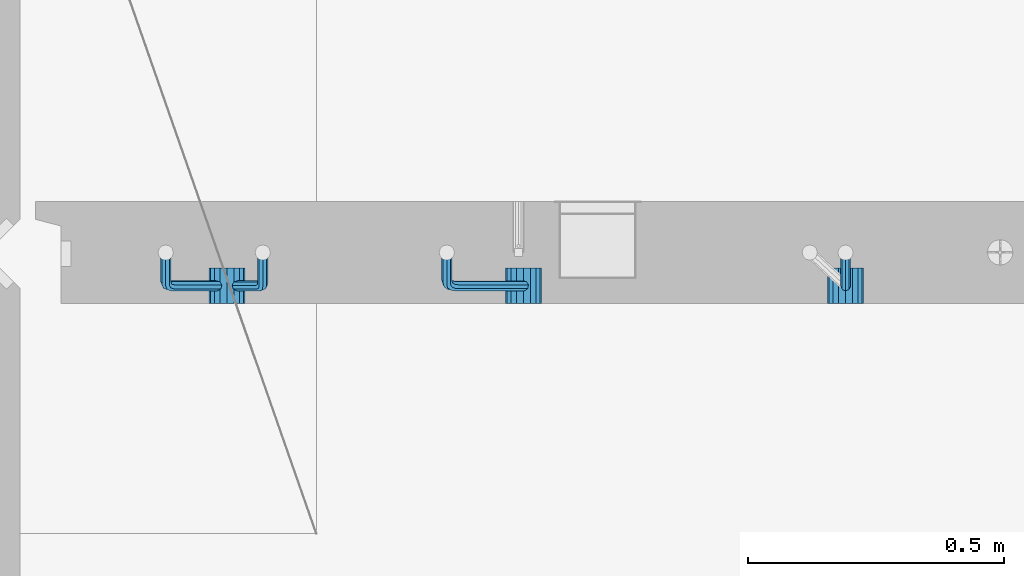
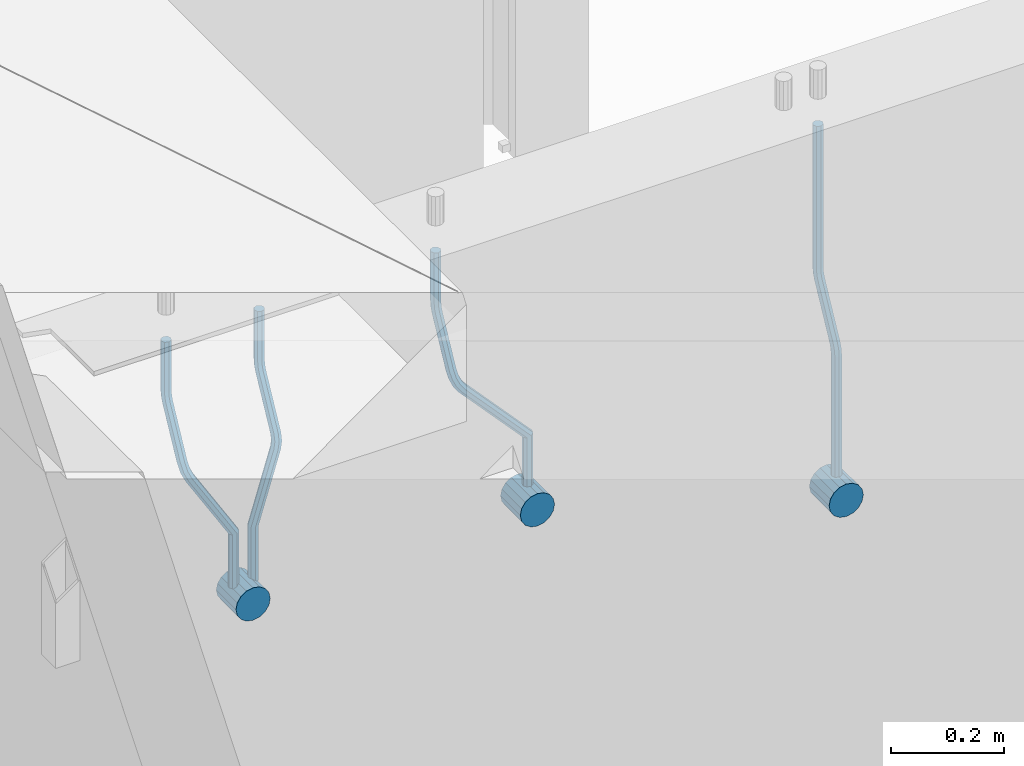
# One storey, part 155 of 349: 7 beams, 1 element without a shape of its own.
"""IFC2X3 building model written with IfcOpenShell, lengths in millimetres."""

from ifc_helpers import new_model, si_unit, frame, origin_with_axes, place, context, subcontext, project, spatial, faceted_brep, material, type_object, element, aggregate, save


model = new_model("IFC2X3")

# Units and contexts
model_context = context("Model", 3, precision=1e-05, world=origin_with_axes())
body_context = subcontext(model_context, "Body", "Model", "MODEL_VIEW")
ifc_project = project(units=[si_unit("LENGTHUNIT", "METRE", prefix="MILLI"), si_unit("AREAUNIT", "SQUARE_METRE"), si_unit("VOLUMEUNIT", "CUBIC_METRE"), si_unit("MASSUNIT", "GRAM", prefix="KILO"), si_unit("TIMEUNIT", "SECOND"), si_unit("PLANEANGLEUNIT", "RADIAN"), si_unit("SOLIDANGLEUNIT", "STERADIAN"), si_unit("THERMODYNAMICTEMPERATUREUNIT", "DEGREE_CELSIUS"), si_unit("LUMINOUSINTENSITYUNIT", "LUMEN")], contexts=[model_context])

# Site, building, storey
site_placement = place(None, origin_with_axes())
site = spatial("IfcSite", under=ifc_project, at=site_placement, CompositionType="ELEMENT")
building_placement = place(site_placement, origin_with_axes())
building = spatial("IfcBuilding", under=site, at=building_placement, CompositionType="ELEMENT")
storey_placement = place(building_placement, origin_with_axes())
storey = spatial("IfcBuildingStorey", under=building, at=storey_placement, Name="4", CompositionType="ELEMENT", Elevation=0.0)

# Assembly, beams
assembly_placement = place(storey_placement, origin_with_axes())
assembly = element("IfcElementAssembly", 1, at=assembly_placement, inside=storey, AssemblyPlace="NOTDEFINED", PredefinedType="REINFORCEMENT_UNIT")
ifc_material = material()
beam_type_1 = type_object("IfcBeamType", Name="D20", PredefinedType="NOTDEFINED")
beam_1_placement = place(assembly_placement, frame((9615.0034031366, 16979.9000008034, 93407.5), z_axis=(-0.000415599999849952, -0.999999913638316, 0.0), x_axis=(0.0, 0.0, -1.0)))
beam_1 = element("IfcBeam", 2, at=beam_1_placement, type_object=beam_type_1, material=ifc_material, Name="JM20", ObjectType="D20", context=body_context, shape_type="Brep", body=[
    faceted_brep([(0.0, -10.0, 0.0), (-4.19531716033816e-08, -7.07106781186667, -7.07106781187031), (308.817759199839, -7.07106784567077, -7.07106781098628), (308.817759199388, -10.0000000315576, 1.18961906991899e-09), (0.0, 0.0, -10.0), (308.817759200625, -3.38059180648997e-08, -9.99999999911961), (4.196772351861e-08, 7.07106781186303, -7.07106781186667), (308.817759201396, 7.07106777806075, -7.07106781098992), (0.0, 10.0, 0.0), (308.817759201687, 9.99999996619408, 8.76752892509103e-10), (4.196772351861e-08, 7.07106781185939, 7.07106781185939), (308.817759201353, 7.07106777805893, 7.07106781273978), (0.0, 0.0, 10.0), (308.817759200567, -3.38059180648997e-08, 10.0000000008768), (-4.19531716033816e-08, -7.07106781187031, 7.07106781185939), (308.817759199781, -7.07106784567259, 7.07106781274342), (323.108969574154, 0.000717635259206872, -8.27316123493802), (322.412036484602, -7.07038517474393, -5.42844102338131), (320.72809124495, -9.99940192615759, 1.43915193649809), (319.043566138222, -7.07055433041933, 8.30667482965873), (318.345233125816, 0.000478413006931078, 11.1512258851908), (319.042166215368, 7.07158122300643, 8.30650567364501), (320.726111455049, 10.0005979744237, 1.4389127137656), (322.410636561748, 7.07175037869092, -5.42861017940231), (335.221090258594, 7.07375888522984, -0.59577927861028), (336.577559329642, 0.00282932867594354, -3.19204402394098), (331.949003496353, 10.0023575726736, 5.67282516818887), (328.678043090971, 7.07309199865631, 11.9417058486688), (327.324293285914, 0.00188620863991673, 14.5386374811205), (328.680762356948, -7.06904334791398, 11.9423727357971), (331.952849119407, -9.99764203791528, 5.67376828873239), (335.223809524556, -7.06837646134409, -0.59511239150379), (438.031978881656, -7.04607830785426, 53.0582885393342), (434.761018476231, -9.97534387865016, 59.3271692200688), (439.385728686641, 0.0251274821457628, 50.4613569068679), (438.02925961549, 7.0960570387233, 53.0576216521513), (434.757172853177, 10.0246557262235, 59.326226098925), (431.486212447766, 7.0953901522571, 65.5951067794085), (430.132462642781, 0.0241843622607121, 68.1920384118748), (431.488931713931, -7.04674519431865, 65.5957736665914), (448.364788846782, 0.0265352911246737, 53.8487685030559), (447.667855771331, -7.04456751813632, 56.6934887198913), (445.983910537514, -9.97358426776555, 63.5610816819462), (444.29938542498, -7.04473667025195, 70.428604572935), (443.601052398531, 0.0262960739091795, 73.2731556232175), (444.297985473939, 7.09739888316835, 70.4284354063821), (445.981930707741, 10.0264156328012, 63.5608424443053), (447.666455820276, 7.09756803528398, 56.6933195533311), (457.892262743961, 7.0980815803614, 57.9289265681182), (457.892262772089, 0.0270137655697908, 54.999994387068), (457.892262732348, 10.0270137755506, 64.9999943770345), (457.892262744092, 7.09808159448221, 72.0710621918224), (457.89226277222, 0.0270137855477515, 74.9999943870425), (457.89226280032, -7.04405402924385, 72.0710622060069), (457.892262811918, -9.97298622770904, 64.9999943967923), (457.892262800189, -7.04405404336103, 57.9289265822954), (717.500000028129, -7.04405301280349, 57.928926581666), (717.500000039799, -9.97298519384276, 64.9999943964685), (717.499999999956, 0.0270147961218754, 54.999994386435), (717.499999971798, 7.09808261092803, 57.9289265674743), (717.499999960128, 10.0270148061572, 64.9999943763978), (717.499999971813, 7.09808262511979, 72.071062191204), (717.499999999985, 0.0270148161926045, 74.999994386435), (717.500000028143, -7.04405299861173, 72.0710622053957)], [[[0, 1, 2, 3]], [[1, 4, 5, 2]], [[4, 6, 7, 5]], [[6, 8, 9, 7]], [[8, 10, 11, 9]], [[10, 12, 13, 11]], [[12, 14, 15, 13]], [[14, 0, 3, 15]], [[14, 12, 10, 8, 6, 4, 1, 0]], [[2, 5, 16, 17]], [[3, 2, 17, 18]], [[15, 3, 18, 19]], [[13, 15, 19, 20]], [[11, 13, 20, 21]], [[9, 11, 21, 22]], [[7, 9, 22, 23]], [[5, 7, 23, 16]], [[23, 24, 25, 16]], [[22, 26, 24, 23]], [[21, 27, 26, 22]], [[20, 28, 27, 21]], [[19, 29, 28, 20]], [[18, 30, 29, 19]], [[17, 31, 30, 18]], [[16, 25, 31, 17]], [[30, 31, 32, 33]], [[31, 25, 34, 32]], [[25, 24, 35, 34]], [[24, 26, 36, 35]], [[26, 27, 37, 36]], [[27, 28, 38, 37]], [[28, 29, 39, 38]], [[29, 30, 33, 39]], [[32, 34, 40, 41]], [[33, 32, 41, 42]], [[39, 33, 42, 43]], [[38, 39, 43, 44]], [[37, 38, 44, 45]], [[36, 37, 45, 46]], [[35, 36, 46, 47]], [[34, 35, 47, 40]], [[47, 48, 49, 40]], [[46, 50, 48, 47]], [[45, 51, 50, 46]], [[44, 52, 51, 45]], [[43, 53, 52, 44]], [[42, 54, 53, 43]], [[41, 55, 54, 42]], [[40, 49, 55, 41]], [[54, 55, 56, 57]], [[55, 49, 58, 56]], [[49, 48, 59, 58]], [[48, 50, 60, 59]], [[50, 51, 61, 60]], [[51, 52, 62, 61]], [[52, 53, 63, 62]], [[53, 54, 57, 63]], [[58, 59, 60, 61, 62, 63, 57, 56]]]),
])
beam_2_placement = place(assembly_placement, frame((8835.00340324668, 16979.9000008034, 93407.5), z_axis=(-0.000415599999849952, -0.999999913638316, 0.0), x_axis=(0.0, 0.0, -1.0)))
beam_2 = element("IfcBeam", 3, at=beam_2_placement, type_object=beam_type_1, material=ifc_material, Name="JM20", ObjectType="D20", context=body_context, shape_type="Brep", body=[
    faceted_brep([(0.0, -10.0, 0.0), (-4.19531716033816e-08, -7.07106781186667, -7.07106781187031), (108.817745274035, -7.07106780534923, -7.07106781138282), (108.817745274282, -9.99999999387728, 6.25732354819775e-10), (0.0, 0.0, -10.0), (108.817745273627, 6.5174390329048e-09, -9.99999999951979), (4.196772351861e-08, 7.07106781186303, -7.07106781186667), (108.817745273191, 7.07106781838229, -7.07106781138646), (0.0, 10.0, 0.0), (108.817745272972, 10.0000000065156, 4.80213202536106e-10), (4.196772351861e-08, 7.07106781185939, 7.07106781185939), (108.817745273118, 7.07106781838047, 7.07106781234688), (0.0, 0.0, 10.0), (108.817745273511, 6.51562004350126e-09, 10.0000000004839), (-4.19531716033816e-08, -7.07106781187031, 7.07106781185939), (108.817745273947, -7.07106780535105, 7.07106781234688), (123.108954183059, 0.000717681035894202, -8.27316159443217), (122.412021172189, -7.07038512938016, -5.42844136475105), (120.72807610796, -9.99940188179062, 1.43915163770362), (119.043551170704, -7.07055428705462, 8.30667457294476), (118.345218222516, 0.000478455955089885, 11.1512256454189), (119.0421512334, 7.07158126637114, 8.30650541574869), (120.726096297614, 10.0005980187834, 1.43891241329038), (122.410621234856, 7.0717504240456, -5.42861052196531), (135.22107377628, 7.07375894905454, -0.595780608462519), (136.577542729705, 0.00282939387761871, -3.19204541917861), (131.948987323645, 10.0023576331841, 5.67282400158729), (128.678027238435, 7.07309205585807, 11.9417048475552), (127.324277576598, 0.00188626447015849, 14.5386365507547), (128.680746529979, -7.06904329070858, 11.9423717400241), (131.952832982774, -9.99764197422519, 5.67376712984333), (135.223793067897, -7.06837639751029, -0.595113715968182), (228.618473932263, -7.04811975626581, 48.1455814515648), (225.347513847039, -9.97738533437769, 54.4144622980784), (229.972223594217, 0.0230860351002775, 45.5486497482525), (228.615754640981, 7.0940155903063, 48.1449145588849), (225.343668188434, 10.0226142745032, 54.413519168902), (222.072708103209, 7.0933486972317, 60.6824000149136), (220.71895844127, 0.0221429058692593, 63.2793317182222), (222.075427394506, -7.04878664933858, 60.6830669075935), (242.359530626607, -5.11807977741773, 54.2178725378544), (240.589998539246, -7.8364579297413, 61.1502473240325), (237.467032239641, -4.88691414189452, 67.4847494116439), (234.820023031163, 2.00274883800921, 69.5107133886158), (234.199553008453, 8.79665987653607, 66.041357034137), (235.9690850958, 11.515038028856, 59.108982247948), (239.092051395462, 8.56549424101649, 52.7744801603476), (241.739060603926, 1.67583126110367, 50.7485161833647), (253.320593995435, 6.49475796966908, 54.0461912154642), (255.884193780192, 0.509358169847474, 58.0688258176233), (249.403367901468, 12.8559000820806, 55.7104792064529), (246.427173417251, 15.8665137298067, 62.0867724571763), (246.135424907392, 13.7630222690877, 69.4399248590198), (248.699024692221, 7.77762246929342, 73.462559461208), (252.616250786203, 1.41648035689104, 71.7982714702011), (255.592445270362, -1.59413329085874, 65.4219782194778), (263.775218458322, 14.0880763316163, 55.1735662778046), (268.092877162446, 9.37667043252804, 59.3853499298057), (258.711370403718, 19.6164132468075, 56.7142082202008), (255.867666511243, 22.72325639054, 63.1047886019151), (256.909909953785, 21.588659185405, 70.6017921067651), (261.227568657952, 16.8772532863513, 74.8135757587734), (266.291416712571, 11.348916371182, 73.2729338163554), (269.135120604697, 8.24207322799703, 66.8823534341354), (411.777331932535, 141.004054536572, 59.330645583992), (412.819575375106, 139.86945733149, 66.8276490888165), (407.459673228295, 145.71546043558, 55.1188619320019), (402.395825173633, 151.243797350722, 56.6595038743981), (399.552121281173, 154.350640494475, 63.0500842560868), (400.594364723744, 153.216043289394, 70.547087760915), (404.912023427984, 148.504637390388, 74.7588714129015), (409.975871482646, 142.976300475242, 73.2182294705053), (412.588360762704, 141.747027069805, 59.3303368045817), (413.18825896435, 140.207203377095, 66.8275087215443), (410.103187350978, 148.137147940774, 55.1178554785947), (407.188519608899, 155.634319848998, 56.6576791731022), (405.551730369989, 159.846801170075, 63.047800051525), (406.151628571635, 158.306977477367, 70.5449719684912), (408.636801983361, 151.916856606398, 74.7574532944818), (411.551469725426, 144.419684698174, 73.2176295999743), (413.688258959737, 141.747027073105, 59.3303368045781), (413.68825896435, 140.207203378595, 66.8275087215443), (413.688258940572, 148.137147951529, 55.1178554785911), (413.688258918075, 155.634319868494, 56.6576791730986), (413.688258905444, 159.846801194481, 63.0478000515213), (413.688258910042, 158.306977499973, 70.5449719684912), (413.688258929222, 151.916856621549, 74.7574532944782), (413.688258951704, 144.419684704584, 73.2176295999707), (517.499999574822, 141.74702738449, 59.3303368045817), (517.499999579435, 140.207203689981, 66.8275087215443), (517.499999555657, 148.137148262915, 55.1178554785947), (517.499999533175, 155.634320179879, 56.6576791731022), (517.499999520529, 159.846801505866, 63.047800051525), (517.499999525127, 158.306977811359, 70.5449719684912), (517.499999544307, 151.916856932934, 74.7574532944818), (517.499999566789, 144.41968501597, 73.2176295999743)], [[[0, 1, 2, 3]], [[1, 4, 5, 2]], [[4, 6, 7, 5]], [[6, 8, 9, 7]], [[8, 10, 11, 9]], [[10, 12, 13, 11]], [[12, 14, 15, 13]], [[14, 0, 3, 15]], [[14, 12, 10, 8, 6, 4, 1, 0]], [[2, 5, 16, 17]], [[3, 2, 17, 18]], [[15, 3, 18, 19]], [[13, 15, 19, 20]], [[11, 13, 20, 21]], [[9, 11, 21, 22]], [[7, 9, 22, 23]], [[5, 7, 23, 16]], [[23, 24, 25, 16]], [[22, 26, 24, 23]], [[21, 27, 26, 22]], [[20, 28, 27, 21]], [[19, 29, 28, 20]], [[18, 30, 29, 19]], [[17, 31, 30, 18]], [[16, 25, 31, 17]], [[30, 31, 32, 33]], [[31, 25, 34, 32]], [[25, 24, 35, 34]], [[24, 26, 36, 35]], [[26, 27, 37, 36]], [[27, 28, 38, 37]], [[28, 29, 39, 38]], [[29, 30, 33, 39]], [[33, 32, 40, 41]], [[39, 33, 41, 42]], [[38, 39, 42, 43]], [[37, 38, 43, 44]], [[36, 37, 44, 45]], [[35, 36, 45, 46]], [[34, 35, 46, 47]], [[32, 34, 47, 40]], [[47, 48, 49, 40]], [[46, 50, 48, 47]], [[45, 51, 50, 46]], [[44, 52, 51, 45]], [[43, 53, 52, 44]], [[42, 54, 53, 43]], [[41, 55, 54, 42]], [[40, 49, 55, 41]], [[48, 56, 57, 49]], [[50, 58, 56, 48]], [[51, 59, 58, 50]], [[52, 60, 59, 51]], [[53, 61, 60, 52]], [[54, 62, 61, 53]], [[55, 63, 62, 54]], [[49, 57, 63, 55]], [[63, 57, 64, 65]], [[57, 56, 66, 64]], [[56, 58, 67, 66]], [[58, 59, 68, 67]], [[59, 60, 69, 68]], [[60, 61, 70, 69]], [[61, 62, 71, 70]], [[62, 63, 65, 71]], [[65, 64, 72, 73]], [[64, 66, 74, 72]], [[66, 67, 75, 74]], [[67, 68, 76, 75]], [[68, 69, 77, 76]], [[69, 70, 78, 77]], [[70, 71, 79, 78]], [[71, 65, 73, 79]], [[73, 72, 80, 81]], [[72, 74, 82, 80]], [[74, 75, 83, 82]], [[75, 76, 84, 83]], [[76, 77, 85, 84]], [[77, 78, 86, 85]], [[78, 79, 87, 86]], [[79, 73, 81, 87]], [[81, 80, 88, 89]], [[80, 82, 90, 88]], [[82, 83, 91, 90]], [[83, 84, 92, 91]], [[84, 85, 93, 92]], [[85, 86, 94, 93]], [[86, 87, 95, 94]], [[87, 81, 89, 95]], [[90, 91, 92, 93, 94, 95, 89, 88]]]),
])
beam_3_placement = place(assembly_placement, frame((8475.00340324668, 16979.9000008034, 93407.5), z_axis=(-0.000415599999849952, -0.999999913638316, 0.0), x_axis=(0.0, 0.0, -1.0)))
beam_3 = element("IfcBeam", 4, at=beam_3_placement, type_object=beam_type_1, material=ifc_material, Name="JM20", ObjectType="D20", context=body_context, shape_type="Brep", body=[
    faceted_brep([(0.0, -10.0, 0.0), (-4.19531716033816e-08, -7.07106781186667, -7.07106781187031), (108.817745274035, -7.07106780534923, -7.07106781138282), (108.817745274282, -9.99999999387728, 6.25732354819775e-10), (0.0, 0.0, -10.0), (108.817745273627, 6.5174390329048e-09, -9.99999999951979), (4.196772351861e-08, 7.07106781186303, -7.07106781186667), (108.817745273191, 7.07106781838229, -7.07106781138646), (0.0, 10.0, 0.0), (108.817745272972, 10.0000000065156, 4.80213202536106e-10), (4.196772351861e-08, 7.07106781185939, 7.07106781185939), (108.817745273118, 7.07106781838047, 7.07106781234688), (0.0, 0.0, 10.0), (108.817745273511, 6.51562004350126e-09, 10.0000000004839), (-4.19531716033816e-08, -7.07106781187031, 7.07106781185939), (108.817745273947, -7.07106780535105, 7.07106781234688), (123.108954183059, 0.000717681035894202, -8.27316159443217), (122.412021172189, -7.07038512938016, -5.42844136475105), (120.72807610796, -9.99940188179062, 1.43915163770362), (119.043551170704, -7.07055428705462, 8.30667457294476), (118.345218222516, 0.000478455955089885, 11.1512256454189), (119.0421512334, 7.07158126637114, 8.30650541574869), (120.726096297614, 10.0005980187834, 1.43891241329038), (122.410621234856, 7.0717504240456, -5.42861052196531), (135.22107377628, 7.07375894905454, -0.595780608462519), (136.577542729705, 0.00282939387761871, -3.19204541917861), (131.948987323645, 10.0023576331841, 5.67282400158729), (128.678027238435, 7.07309205585807, 11.9417048475552), (127.324277576598, 0.00188626447015849, 14.5386365507547), (128.680746529979, -7.06904329070858, 11.9423717400241), (131.952832982774, -9.99764197422519, 5.67376712984333), (135.223793067897, -7.06837639751029, -0.595113715968182), (236.184987141853, -7.04647863304126, 52.0943835719445), (232.914027056744, -9.97574421112949, 58.3632644184945), (237.538736803792, 0.0247271583230031, 49.4974518686358), (236.182267850556, 7.09565671352902, 52.093716679261), (232.910181397994, 10.0242553977168, 58.3623212892744), (229.639221312784, 7.0949898204417, 64.631202135286), (228.28547165083, 0.0237840290774329, 67.2281338385947), (229.64194060408, -7.04714552612859, 64.6318690279659), (248.6361426574, 6.07228546495571, 56.8411920703111), (248.347225361111, -0.863437898962729, 53.6176983169717), (246.616285773896, -7.90364889308694, 56.0708434545886), (244.457284830249, -10.9242873990424, 62.7636083320067), (243.134936001807, -8.15590434705155, 69.7754620538217), (243.423853298023, -1.22018098313129, 72.9989558071647), (245.154792885252, 5.82003001100384, 70.5458106695442), (247.313793828915, 8.84066851695206, 63.8530457921224), (262.262810178814, 5.37582167724941, 65.733133839356), (261.561593060862, 3.07645584421334, 58.4667829613572), (261.257873569193, 2.08769693226714, 72.5710415482208), (259.135461468584, -4.86177950991259, 74.9749524903455), (257.138854100602, -11.4016986008392, 71.5366882385752), (256.437636982591, -13.7010644331713, 64.2703373600561), (257.442573592241, -10.4129396888893, 57.4324296517152), (259.564985692865, -3.46346324671867, 55.0285187095906), (405.56030258059, -55.6424869289785, 57.4512270528103), (404.555365971013, -58.9306116739535, 64.2891347616751), (407.682714681185, -48.6930104868225, 55.0473161106529), (409.679322049255, -42.153091395905, 58.4855803623905), (410.380539167294, -39.8537255628671, 65.7519312403674), (409.375602557717, -43.1418503078439, 72.5898389492322), (407.253190457122, -50.09132675, 74.993749891386), (405.256583089053, -56.6312458409175, 71.5554856396557), (408.394915116543, -56.5080702894629, 57.4515867892878), (407.881249744809, -59.9462106727442, 64.2895568446584), (409.479769216079, -49.2417629119063, 55.0475441721828), (410.500319225088, -42.4037928534744, 58.4856845539216), (410.858740789379, -39.9997502352981, 65.751991928224), (410.345075417616, -43.4378906185757, 72.5899619835945), (409.26022131808, -50.7041979961323, 74.9940046006996), (408.239671309086, -57.5421680545642, 71.5558642189608), (411.358740838899, -56.5080702805735, 57.4515867892915), (411.358740849202, -59.9462106623123, 64.2895568446584), (411.358740817101, -49.2417629062693, 55.0475441721828), (411.358740796582, -42.4037928508988, 58.4856845539216), (411.358740789379, -39.9997502337974, 65.751991928224), (411.358740799667, -43.4378906155343, 72.5899619835945), (411.358740821452, -50.7041979898386, 74.9940046006996), (411.35874084197, -57.5421680452091, 71.5558642189608), (527.500000169515, -56.5080699322043, 57.4515867892878), (527.500000179818, -59.9462103139449, 64.2895568446584), (527.500000147716, -49.2417625579019, 55.0475441721828), (527.500000127198, -42.4037925025295, 58.4856845539216), (527.500000119981, -39.9997498854282, 65.751991928224), (527.500000130283, -43.4378902671669, 72.5899619835945), (527.500000152068, -50.7041976414694, 74.9940046006996), (527.500000172586, -57.5421676968399, 71.5558642189608)], [[[0, 1, 2, 3]], [[1, 4, 5, 2]], [[4, 6, 7, 5]], [[6, 8, 9, 7]], [[8, 10, 11, 9]], [[10, 12, 13, 11]], [[12, 14, 15, 13]], [[14, 0, 3, 15]], [[14, 12, 10, 8, 6, 4, 1, 0]], [[2, 5, 16, 17]], [[3, 2, 17, 18]], [[15, 3, 18, 19]], [[13, 15, 19, 20]], [[11, 13, 20, 21]], [[9, 11, 21, 22]], [[7, 9, 22, 23]], [[5, 7, 23, 16]], [[23, 24, 25, 16]], [[22, 26, 24, 23]], [[21, 27, 26, 22]], [[20, 28, 27, 21]], [[19, 29, 28, 20]], [[18, 30, 29, 19]], [[17, 31, 30, 18]], [[16, 25, 31, 17]], [[30, 31, 32, 33]], [[31, 25, 34, 32]], [[25, 24, 35, 34]], [[24, 26, 36, 35]], [[26, 27, 37, 36]], [[27, 28, 38, 37]], [[28, 29, 39, 38]], [[29, 30, 33, 39]], [[34, 35, 40, 41]], [[32, 34, 41, 42]], [[33, 32, 42, 43]], [[39, 33, 43, 44]], [[38, 39, 44, 45]], [[37, 38, 45, 46]], [[36, 37, 46, 47]], [[35, 36, 47, 40]], [[47, 48, 49, 40]], [[46, 50, 48, 47]], [[45, 51, 50, 46]], [[44, 52, 51, 45]], [[43, 53, 52, 44]], [[42, 54, 53, 43]], [[41, 55, 54, 42]], [[40, 49, 55, 41]], [[53, 54, 56, 57]], [[54, 55, 58, 56]], [[55, 49, 59, 58]], [[49, 48, 60, 59]], [[48, 50, 61, 60]], [[50, 51, 62, 61]], [[51, 52, 63, 62]], [[52, 53, 57, 63]], [[57, 56, 64, 65]], [[56, 58, 66, 64]], [[58, 59, 67, 66]], [[59, 60, 68, 67]], [[60, 61, 69, 68]], [[61, 62, 70, 69]], [[62, 63, 71, 70]], [[63, 57, 65, 71]], [[65, 64, 72, 73]], [[64, 66, 74, 72]], [[66, 67, 75, 74]], [[67, 68, 76, 75]], [[68, 69, 77, 76]], [[69, 70, 78, 77]], [[70, 71, 79, 78]], [[71, 65, 73, 79]], [[73, 72, 80, 81]], [[72, 74, 82, 80]], [[74, 75, 83, 82]], [[75, 76, 84, 83]], [[76, 77, 85, 84]], [[77, 78, 86, 85]], [[78, 79, 87, 86]], [[79, 73, 81, 87]], [[82, 83, 84, 85, 86, 87, 81, 80]]]),
])
beam_4_placement = place(assembly_placement, frame((8285.00340324668, 16979.9000008034, 93407.5), z_axis=(-0.000415599999849952, -0.999999913638316, 0.0), x_axis=(0.0, 0.0, -1.0)))
beam_4 = element("IfcBeam", 5, at=beam_4_placement, type_object=beam_type_1, material=ifc_material, Name="JM20", ObjectType="D20", context=body_context, shape_type="Brep", body=[
    faceted_brep([(0.0, -10.0, 0.0), (-4.19531716033816e-08, -7.07106781186667, -7.07106781187031), (108.817745274035, -7.07106780534923, -7.07106781138282), (108.817745274282, -9.99999999387728, 6.25732354819775e-10), (0.0, 0.0, -10.0), (108.817745273627, 6.5174390329048e-09, -9.99999999951979), (4.196772351861e-08, 7.07106781186303, -7.07106781186667), (108.817745273191, 7.07106781838229, -7.07106781138646), (0.0, 10.0, 0.0), (108.817745272972, 10.0000000065156, 4.80213202536106e-10), (4.196772351861e-08, 7.07106781185939, 7.07106781185939), (108.817745273118, 7.07106781838047, 7.07106781234688), (0.0, 0.0, 10.0), (108.817745273511, 6.51562004350126e-09, 10.0000000004839), (-4.19531716033816e-08, -7.07106781187031, 7.07106781185939), (108.817745273947, -7.07106780535105, 7.07106781234688), (123.108954183059, 0.000717681035894202, -8.27316159443217), (122.412021172189, -7.07038512938016, -5.42844136475105), (120.72807610796, -9.99940188179062, 1.43915163770362), (119.043551170704, -7.07055428705462, 8.30667457294476), (118.345218222516, 0.000478455955089885, 11.1512256454189), (119.0421512334, 7.07158126637114, 8.30650541574869), (120.726096297614, 10.0005980187834, 1.43891241329038), (122.410621234856, 7.0717504240456, -5.42861052196531), (135.22107377628, 7.07375894905454, -0.595780608462519), (136.577542729705, 0.00282939387761871, -3.19204541917861), (131.948987323645, 10.0023576331841, 5.67282400158729), (128.678027238435, 7.07309205585807, 11.9417048475552), (127.324277576598, 0.00188626447015849, 14.5386365507547), (128.680746529979, -7.06904329070858, 11.9423717400241), (131.952832982774, -9.99764197422519, 5.67376712984333), (135.223793067897, -7.06837639751029, -0.595113715968182), (232.402437428042, -7.04729904112355, 50.1203514230874), (229.131477342933, -9.97656461926999, 56.3892322695465), (233.756187089995, 0.0239067502407124, 47.5234197197824), (232.399718136745, 7.09483630544673, 50.1196845304112), (229.127631684183, 10.0234349896364, 56.3882891404246), (225.856671598973, 7.09416941235941, 62.6571699864289), (224.502921937034, 0.0229636209951423, 65.2541016897412), (225.859390890269, -7.04796593420906, 62.6578368791124), (249.189096393879, -4.47246690703469, 56.6819566015656), (248.077205390815, -7.070562329116, 63.794778990592), (245.438615273073, -4.04479441522199, 70.3110060036124), (242.818976346156, 2.83238302726022, 72.4135202319376), (241.752837564854, 9.53241272338892, 68.8706973556764), (242.864728567991, 12.130508145472, 61.7578749666827), (245.503318685674, 9.10474023159077, 55.2416479536478), (248.122957612577, 2.22756278908673, 53.1391337253044), (262.227655998417, 8.55574368060479, 55.0905560343417), (265.66954071114, 2.92161058118472, 58.9620696407692), (258.367889273839, 14.876528294435, 57.021495303452), (256.351239537093, 18.1813345207174, 63.6237694123665), (257.359032853405, 16.5342516931214, 71.0298557306051), (260.800917566128, 10.9001185936977, 74.9013693370434), (264.660684290735, 4.57933397990018, 72.9704300679259), (266.677334027001, 1.27452775464917, 66.3681559586585), (410.721160764631, 91.5081613346811, 58.9252530669619), (411.728954081002, 89.861078507096, 66.3313393852004), (407.279276051908, 97.1422944340902, 55.053739460498), (403.419509327403, 103.46307904791, 56.9846787295719), (401.402859590729, 106.767885274196, 63.5869528384683), (402.410652907114, 105.12080244661, 70.9930391567141), (405.852537619838, 99.4866693472013, 74.8645527631779), (409.712304344357, 93.1658847333838, 72.9336134941077), (411.611923002652, 92.0521714889783, 58.9250269763252), (412.155668410225, 90.1216833219078, 66.3312310778347), (409.754886469877, 98.6542099015223, 55.0531111083837), (407.672385626982, 106.060413996784, 56.9835992770786), (406.584321224072, 109.932329861462, 63.5856376951961), (407.12806663166, 108.001841694397, 70.9918417967092), (408.985103164436, 101.399803281851, 74.8637576646506), (411.06760400733, 93.9935991865859, 72.9332694959521), (412.655668404448, 92.0521714921069, 58.9250269763288), (412.655668410225, 90.1216833234084, 66.3312310778347), (412.655668384643, 98.6542099102207, 55.0531111083837), (412.655668362422, 106.06041401173, 56.9835992770822), (412.65566835081, 109.932329879672, 63.5856376951961), (412.655668356587, 108.001841710977, 70.9918417967056), (412.655668376392, 101.399803292861, 74.8637576646506), (412.655668398613, 93.9935991913499, 72.9332694959521), (527.499999723892, 92.0521718365853, 58.9250269763252), (527.499999729669, 90.1216836678886, 66.3312310778347), (527.499999704101, 98.6542102546991, 55.0531111083837), (527.499999681881, 106.060414356209, 56.9835992770786), (527.499999670254, 109.93233022415, 63.5856376951924), (527.499999676045, 108.001842055455, 70.9918417967056), (527.499999695836, 101.399803637341, 74.863757664647), (527.499999718057, 93.9935995358301, 72.9332694959521)], [[[0, 1, 2, 3]], [[1, 4, 5, 2]], [[4, 6, 7, 5]], [[6, 8, 9, 7]], [[8, 10, 11, 9]], [[10, 12, 13, 11]], [[12, 14, 15, 13]], [[14, 0, 3, 15]], [[14, 12, 10, 8, 6, 4, 1, 0]], [[2, 5, 16, 17]], [[3, 2, 17, 18]], [[15, 3, 18, 19]], [[13, 15, 19, 20]], [[11, 13, 20, 21]], [[9, 11, 21, 22]], [[7, 9, 22, 23]], [[5, 7, 23, 16]], [[23, 24, 25, 16]], [[22, 26, 24, 23]], [[21, 27, 26, 22]], [[20, 28, 27, 21]], [[19, 29, 28, 20]], [[18, 30, 29, 19]], [[17, 31, 30, 18]], [[16, 25, 31, 17]], [[30, 31, 32, 33]], [[31, 25, 34, 32]], [[25, 24, 35, 34]], [[24, 26, 36, 35]], [[26, 27, 37, 36]], [[27, 28, 38, 37]], [[28, 29, 39, 38]], [[29, 30, 33, 39]], [[33, 32, 40, 41]], [[39, 33, 41, 42]], [[38, 39, 42, 43]], [[37, 38, 43, 44]], [[36, 37, 44, 45]], [[35, 36, 45, 46]], [[34, 35, 46, 47]], [[32, 34, 47, 40]], [[47, 48, 49, 40]], [[46, 50, 48, 47]], [[45, 51, 50, 46]], [[44, 52, 51, 45]], [[43, 53, 52, 44]], [[42, 54, 53, 43]], [[41, 55, 54, 42]], [[40, 49, 55, 41]], [[55, 49, 56, 57]], [[49, 48, 58, 56]], [[48, 50, 59, 58]], [[50, 51, 60, 59]], [[51, 52, 61, 60]], [[52, 53, 62, 61]], [[53, 54, 63, 62]], [[54, 55, 57, 63]], [[57, 56, 64, 65]], [[56, 58, 66, 64]], [[58, 59, 67, 66]], [[59, 60, 68, 67]], [[60, 61, 69, 68]], [[61, 62, 70, 69]], [[62, 63, 71, 70]], [[63, 57, 65, 71]], [[65, 64, 72, 73]], [[64, 66, 74, 72]], [[66, 67, 75, 74]], [[67, 68, 76, 75]], [[68, 69, 77, 76]], [[69, 70, 78, 77]], [[70, 71, 79, 78]], [[71, 65, 73, 79]], [[73, 72, 80, 81]], [[72, 74, 82, 80]], [[74, 75, 83, 82]], [[75, 76, 84, 83]], [[76, 77, 85, 84]], [[77, 78, 86, 85]], [[78, 79, 87, 86]], [[79, 73, 81, 87]], [[82, 83, 84, 85, 86, 87, 81, 80]]]),
])
beam_type_2 = type_object("IfcBeamType", Name="D70", PredefinedType="NOTDEFINED")
beam_5_placement = place(assembly_placement, frame((9615.00340323833, 16879.9000008034, 92654.9999989631), z_axis=(0.0, 0.0, 1.0), x_axis=(0.0, 1.0, 0.0)))
beam_5 = element("IfcBeam", 6, at=beam_5_placement, type_object=beam_type_2, material=ifc_material, ObjectType="D70", context=body_context, shape_type="Brep", body=[
    faceted_brep([(0.0, -35.0, 0.0), (0.0, -32.3357836378964, -13.3939201327739), (70.0, -32.3357836378964, -13.3939201327739), (70.0, -35.0, 0.0), (0.0, -24.7487373415279, -24.7487373415352), (70.0, -24.7487373415279, -24.7487373415352), (0.0, -13.3939201327776, -32.3357836379), (70.0, -13.3939201327776, -32.3357836379), (0.0, 0.0, -35.0), (70.0, 0.0, -35.0), (0.0, 13.3939201327776, -32.3357836379), (70.0, 13.3939201327776, -32.3357836379), (0.0, 24.7487373415279, -24.7487373415352), (70.0, 24.7487373415279, -24.7487373415352), (0.0, 32.3357836378964, -13.3939201327739), (70.0, 32.3357836378964, -13.3939201327739), (0.0, 35.0, 0.0), (70.0, 35.0, 0.0), (0.0, 32.3357836378964, 13.3939201327739), (70.0, 32.3357836378964, 13.3939201327739), (0.0, 24.7487373415279, 24.7487373415352), (70.0, 24.7487373415279, 24.7487373415352), (0.0, 13.3939201327776, 32.3357836379), (70.0, 13.3939201327776, 32.3357836379), (0.0, 0.0, 35.0), (70.0, 0.0, 35.0), (0.0, -13.3939201327776, 32.3357836379), (70.0, -13.3939201327776, 32.3357836379), (0.0, -24.7487373415279, 24.7487373415352), (70.0, -24.7487373415279, 24.7487373415352), (0.0, -32.3357836378964, 13.3939201327739), (70.0, -32.3357836378964, 13.3939201327739)], [[[0, 1, 2, 3]], [[1, 4, 5, 2]], [[4, 6, 7, 5]], [[6, 8, 9, 7]], [[8, 10, 11, 9]], [[10, 12, 13, 11]], [[12, 14, 15, 13]], [[14, 16, 17, 15]], [[16, 18, 19, 17]], [[18, 20, 21, 19]], [[20, 22, 23, 21]], [[22, 24, 25, 23]], [[24, 26, 27, 25]], [[26, 28, 29, 27]], [[28, 30, 31, 29]], [[30, 0, 3, 31]], [[5, 7, 9, 11, 13, 15, 17, 19, 21, 23, 25, 27, 29, 31, 3, 2]], [[30, 28, 26, 24, 22, 20, 18, 16, 14, 12, 10, 8, 6, 4, 1, 0]]]),
])
beam_6_placement = place(assembly_placement, frame((8985.00340323833, 16879.9000008034, 92854.9999989631), z_axis=(0.0, 0.0, 1.0), x_axis=(0.0, 1.0, 0.0)))
beam_6 = element("IfcBeam", 7, at=beam_6_placement, type_object=beam_type_2, material=ifc_material, ObjectType="D70", context=body_context, shape_type="Brep", body=[
    faceted_brep([(0.0, -35.0, 0.0), (0.0, -32.3357836378964, -13.3939201327739), (70.0, -32.3357836378964, -13.3939201327739), (70.0, -35.0, 0.0), (0.0, -24.7487373415279, -24.7487373415352), (70.0, -24.7487373415279, -24.7487373415352), (0.0, -13.3939201327776, -32.3357836379), (70.0, -13.3939201327776, -32.3357836379), (0.0, 0.0, -35.0), (70.0, 0.0, -35.0), (0.0, 13.3939201327776, -32.3357836379), (70.0, 13.3939201327776, -32.3357836379), (0.0, 24.7487373415279, -24.7487373415352), (70.0, 24.7487373415279, -24.7487373415352), (0.0, 32.3357836378964, -13.3939201327739), (70.0, 32.3357836378964, -13.3939201327739), (0.0, 35.0, 0.0), (70.0, 35.0, 0.0), (0.0, 32.3357836378964, 13.3939201327739), (70.0, 32.3357836378964, 13.3939201327739), (0.0, 24.7487373415279, 24.7487373415352), (70.0, 24.7487373415279, 24.7487373415352), (0.0, 13.3939201327776, 32.3357836379), (70.0, 13.3939201327776, 32.3357836379), (0.0, 0.0, 35.0), (70.0, 0.0, 35.0), (0.0, -13.3939201327776, 32.3357836379), (70.0, -13.3939201327776, 32.3357836379), (0.0, -24.7487373415279, 24.7487373415352), (70.0, -24.7487373415279, 24.7487373415352), (0.0, -32.3357836378964, 13.3939201327739), (70.0, -32.3357836378964, 13.3939201327739)], [[[0, 1, 2, 3]], [[1, 4, 5, 2]], [[4, 6, 7, 5]], [[6, 8, 9, 7]], [[8, 10, 11, 9]], [[10, 12, 13, 11]], [[12, 14, 15, 13]], [[14, 16, 17, 15]], [[16, 18, 19, 17]], [[18, 20, 21, 19]], [[20, 22, 23, 21]], [[22, 24, 25, 23]], [[24, 26, 27, 25]], [[26, 28, 29, 27]], [[28, 30, 31, 29]], [[30, 0, 3, 31]], [[5, 7, 9, 11, 13, 15, 17, 19, 21, 23, 25, 27, 29, 31, 3, 2]], [[30, 28, 26, 24, 22, 20, 18, 16, 14, 12, 10, 8, 6, 4, 1, 0]]]),
])
beam_7_placement = place(assembly_placement, frame((8405.00340323833, 16879.9000008034, 92854.9999989631), z_axis=(0.0, 0.0, 1.0), x_axis=(0.0, 1.0, 0.0)))
beam_7 = element("IfcBeam", 8, at=beam_7_placement, type_object=beam_type_2, material=ifc_material, ObjectType="D70", context=body_context, shape_type="Brep", body=[
    faceted_brep([(0.0, -35.0, 0.0), (0.0, -32.3357836378964, -13.3939201327739), (70.0, -32.3357836378964, -13.3939201327739), (70.0, -35.0, 0.0), (0.0, -24.7487373415279, -24.7487373415352), (70.0, -24.7487373415279, -24.7487373415352), (0.0, -13.3939201327776, -32.3357836379), (70.0, -13.3939201327776, -32.3357836379), (0.0, 0.0, -35.0), (70.0, 0.0, -35.0), (0.0, 13.3939201327776, -32.3357836379), (70.0, 13.3939201327776, -32.3357836379), (0.0, 24.7487373415279, -24.7487373415352), (70.0, 24.7487373415279, -24.7487373415352), (0.0, 32.3357836378964, -13.3939201327739), (70.0, 32.3357836378964, -13.3939201327739), (0.0, 35.0, 0.0), (70.0, 35.0, 0.0), (0.0, 32.3357836378964, 13.3939201327739), (70.0, 32.3357836378964, 13.3939201327739), (0.0, 24.7487373415279, 24.7487373415352), (70.0, 24.7487373415279, 24.7487373415352), (0.0, 13.3939201327776, 32.3357836379), (70.0, 13.3939201327776, 32.3357836379), (0.0, 0.0, 35.0), (70.0, 0.0, 35.0), (0.0, -13.3939201327776, 32.3357836379), (70.0, -13.3939201327776, 32.3357836379), (0.0, -24.7487373415279, 24.7487373415352), (70.0, -24.7487373415279, 24.7487373415352), (0.0, -32.3357836378964, 13.3939201327739), (70.0, -32.3357836378964, 13.3939201327739)], [[[0, 1, 2, 3]], [[1, 4, 5, 2]], [[4, 6, 7, 5]], [[6, 8, 9, 7]], [[8, 10, 11, 9]], [[10, 12, 13, 11]], [[12, 14, 15, 13]], [[14, 16, 17, 15]], [[16, 18, 19, 17]], [[18, 20, 21, 19]], [[20, 22, 23, 21]], [[22, 24, 25, 23]], [[24, 26, 27, 25]], [[26, 28, 29, 27]], [[28, 30, 31, 29]], [[30, 0, 3, 31]], [[5, 7, 9, 11, 13, 15, 17, 19, 21, 23, 25, 27, 29, 31, 3, 2]], [[30, 28, 26, 24, 22, 20, 18, 16, 14, 12, 10, 8, 6, 4, 1, 0]]]),
])
aggregate(assembly, [beam_5, beam_1, beam_6, beam_2, beam_3, beam_7, beam_4])

save(model, "model.ifc")
